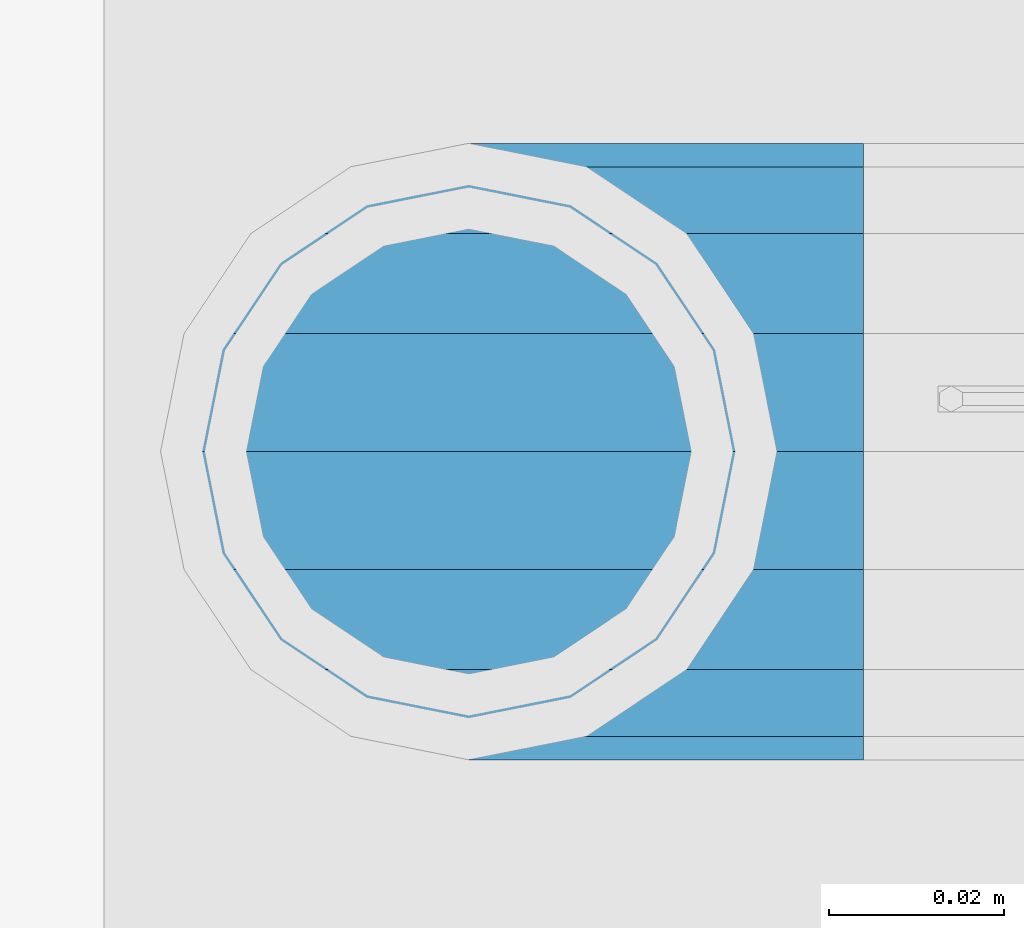
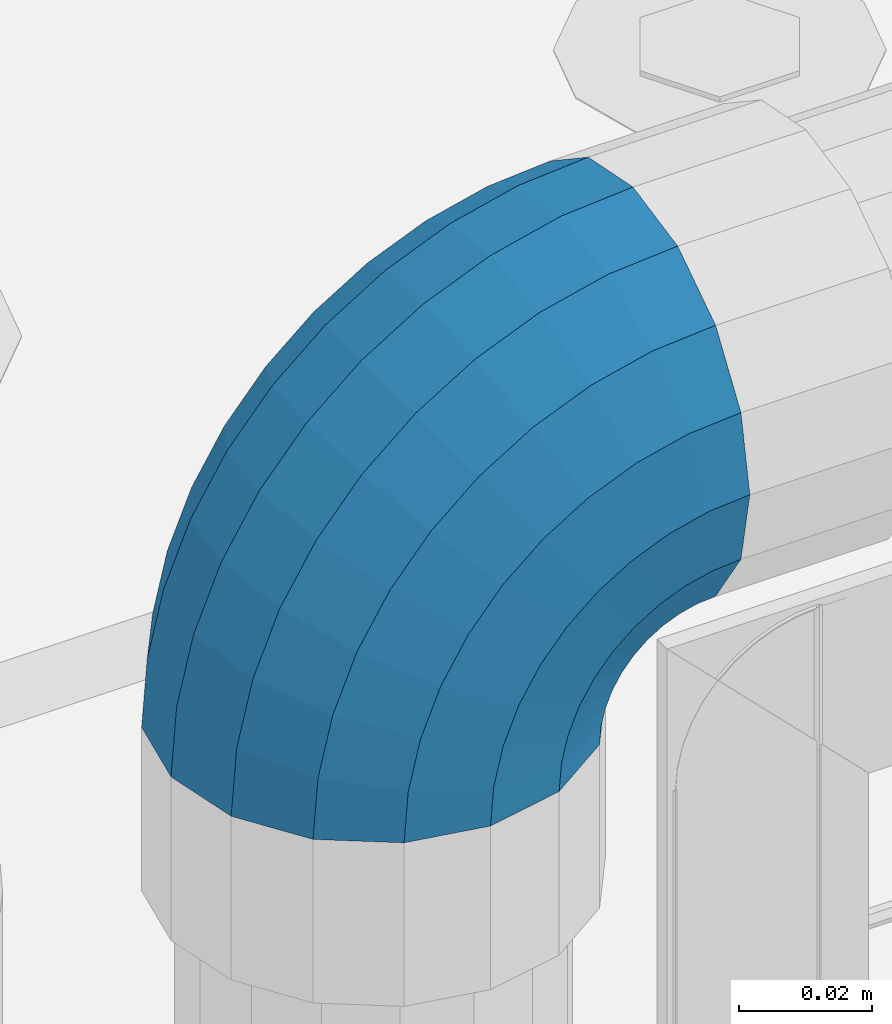
# One storey, part 161 of 240: 1 member.
"""IFC2X3 building model written with IfcOpenShell, lengths in millimetres."""

import ifcopenshell
import ifcopenshell.guid

model = None  # the IFC model being written
_history = None  # IfcOwnerHistory: only IFC2X3 demands one
_inside = {}  # id of a spatial element -> (the spatial element, [elements in it])
_under = {}  # id of a project, library or spatial element -> (it, [spatial elements below it])
_declared = {}  # id of a project -> (the project, [libraries it declares])
_typed = {}  # id of a type object -> (the type object, [elements of that type])
_made_of = {}  # id of a material, layer set ... -> (it, [elements and type objects made of it])


def new_model(schema):
    """Start an empty IFC model of exactly this schema.

    Asked for "IFC4X3", IfcOpenShell would pick the latest addendum, in which some entities
    have other attributes; the version numbers below select the first issue.
    IFC2X3 requires an IfcOwnerHistory on every rooted entity: one is made here for all.
    """
    global model, _history
    if schema == "IFC4X3":
        model = ifcopenshell.file(schema_version=(4, 3, 0, 0))
    else:
        model = ifcopenshell.file(schema=schema)
    _inside.clear()
    _under.clear()
    _declared.clear()
    _typed.clear()
    _made_of.clear()
    _history = None
    if model.schema == "IFC2X3":
        org = make("IfcOrganization", Name="unknown")
        user = make(
            "IfcPersonAndOrganization",
            ThePerson=make("IfcPerson", FamilyName="unknown"),
            TheOrganization=org,
        )
        app = make(
            "IfcApplication",
            ApplicationDeveloper=org,
            Version="unknown",
            ApplicationFullName="unknown",
            ApplicationIdentifier="unknown",
        )
        _history = make(
            "IfcOwnerHistory",
            OwningUser=user,
            OwningApplication=app,
            ChangeAction="ADDED",
            CreationDate=0,
        )
    return model


def make(cls, **values):
    """One entity of the class cls with the attributes given. An attribute that is None is left unset."""
    return model.create_entity(
        cls, **{name: value for name, value in values.items() if value is not None}
    )


def rooted(cls, **values):
    """An entity with a GlobalId (a new one), such as an element, a storey or a relation."""
    return make(cls, GlobalId=ifcopenshell.guid.new(), OwnerHistory=_history, **values)


def si_unit(unit_type, name, prefix=None):
    """IfcSIUnit, for example si_unit("LENGTHUNIT", "METRE", prefix="MILLI")."""
    return make("IfcSIUnit", UnitType=unit_type, Prefix=prefix, Name=name)


def assignment(units):
    """IfcUnitAssignment: the units of a project."""
    return None if units is None else make("IfcUnitAssignment", Units=units)


def point(xyz):
    """IfcCartesianPoint."""
    return None if xyz is None else make("IfcCartesianPoint", Coordinates=xyz)


def direction(xyz):
    """IfcDirection."""
    return None if xyz is None else make("IfcDirection", DirectionRatios=xyz)


def frame(location, z_axis=None, x_axis=None):
    """IfcAxis2Placement3D, a coordinate frame: its origin and axes. An axis left out is left unset."""
    return make(
        "IfcAxis2Placement3D",
        Location=point(location),
        Axis=direction(z_axis),
        RefDirection=direction(x_axis),
    )


def origin_with_axes():
    """The frame at (0, 0, 0) with the z axis (0, 0, 1) and the x axis (1, 0, 0) written out."""
    return frame((0.0, 0.0, 0.0), z_axis=(0.0, 0.0, 1.0), x_axis=(1.0, 0.0, 0.0))


def place(relative_to, where):
    """IfcLocalPlacement: puts the frame where relative to a parent placement (None: the world)."""
    return make(
        "IfcLocalPlacement", PlacementRelTo=relative_to, RelativePlacement=where
    )


def context(
    kind, dimensions, precision=None, world=None, true_north=None, identifier=None
):
    """IfcGeometricRepresentationContext, for example the 3D "Model" context."""
    return make(
        "IfcGeometricRepresentationContext",
        ContextIdentifier=identifier,
        ContextType=kind,
        CoordinateSpaceDimension=dimensions,
        Precision=precision,
        WorldCoordinateSystem=world,
        TrueNorth=true_north,
    )


def subcontext(parent, identifier, kind, view, scale=None):
    """IfcGeometricRepresentationSubContext, for example "Body" below "Model"."""
    return make(
        "IfcGeometricRepresentationSubContext",
        ContextIdentifier=identifier,
        ContextType=kind,
        ParentContext=parent,
        TargetScale=scale,
        TargetView=view,
    )


def project(units=None, contexts=None):
    """IfcProject with its units and contexts."""
    return rooted(
        "IfcProject",
        Name="project",
        RepresentationContexts=contexts,
        UnitsInContext=assignment(units),
    )


def spatial(cls, under=None, at=None, **own):
    """A site, building, storey or space (cls), placed at a placement, below another one or the project."""
    s = rooted(cls, ObjectPlacement=at, **own)
    if under is not None:
        _under.setdefault(under.id(), (under, []))[1].append(s)
    return s


def faces_of(points, faces, orient=None, outer=None):
    """IfcFace entities. A face is a list of loops; a loop is a list of indices into points, from 0.

    orient and outer hold one flag for each loop. By default every Orientation is true, the
    first loop of a face is its IfcFaceOuterBound and the others are IfcFaceBound.
    """
    made = []
    for i, loops in enumerate(faces):
        bounds = []
        for j, loop in enumerate(loops):
            is_outer = j == 0 if outer is None else outer[i][j]
            bounds.append(
                make(
                    "IfcFaceOuterBound" if is_outer else "IfcFaceBound",
                    Bound=make("IfcPolyLoop", Polygon=[points[k] for k in loop]),
                    Orientation=True if orient is None else orient[i][j],
                )
            )
        made.append(make("IfcFace", Bounds=bounds))
    return made


def faceted_brep(points, faces, orient=None, outer=None, voids=None):
    """IfcFacetedBrep: a solid bounded by flat faces; with voids (closed shells), ...WithVoids."""
    shared = [point(p) for p in points]
    hull = make("IfcClosedShell", CfsFaces=faces_of(shared, faces, orient, outer))
    if voids is None:
        return make("IfcFacetedBrep", Outer=hull)
    return make(
        "IfcFacetedBrepWithVoids",
        Outer=hull,
        Voids=[
            make(cls, CfsFaces=faces_of(shared, fs, o, b)) for cls, fs, o, b in voids
        ],
    )


def shape(context_of_items, identifier, shape_type, items):
    """IfcShapeRepresentation: the items that make up one representation, for example the "Body"."""
    return make(
        "IfcShapeRepresentation",
        ContextOfItems=context_of_items,
        RepresentationIdentifier=identifier,
        RepresentationType=shape_type,
        Items=items,
    )


def material(Name=None, Category=None):
    """IfcMaterial."""
    return make("IfcMaterial", Name=Name, Category=Category)


def made_of(thing, what):
    """Note that an element or type object is made of a material, layer set ...; save() writes the relation."""
    if what is not None:
        _made_of.setdefault(what.id(), (what, []))[1].append(thing)
    return thing


def type_object(cls, material=None, **own):
    """A type object (cls), such as IfcWallType, which elements share."""
    return made_of(rooted(cls, **own), material)


def element(
    cls,
    number,
    at=None,
    inside=None,
    cuts=None,
    type_object=None,
    material=None,
    context=None,
    identifier="Body",
    shape_type=None,
    held_by="IfcProductDefinitionShape",
    body=None,
    shapes=None,
    **own,
):
    """One element of the class cls, such as IfcWall. Its Tag is "e" and its number.

    at: its placement. inside: the storey or other place that contains it. cuts: it is an
    opening in that element (IfcRelVoidsElement). A single representation is given by context,
    identifier, shape_type and body (its items); several are given by shapes. held_by: the class
    of the entity that holds the representations. save() writes the other relations.
    """
    e = rooted(cls, Tag="e%d" % number, ObjectPlacement=at, **own)
    if body is not None:
        shapes = [shape(context, identifier, shape_type, body)]
    if shapes is not None:
        e.Representation = make(held_by, Representations=shapes)
    if inside is not None:
        _inside.setdefault(inside.id(), (inside, []))[1].append(e)
    if cuts is not None:
        rooted(
            "IfcRelVoidsElement", RelatingBuildingElement=cuts, RelatedOpeningElement=e
        )
    if type_object is not None:
        _typed.setdefault(type_object.id(), (type_object, []))[1].append(e)
    return made_of(e, material)


def aggregate(whole, parts):
    """IfcRelAggregates: a whole, such as a stair, and the parts it consists of."""
    return rooted("IfcRelAggregates", RelatingObject=whole, RelatedObjects=parts)


def save(model, path):
    """Write the relations noted so far, then the file.

    IfcRelAggregates (storeys below a building ...), IfcRelContainedInSpatialStructure (elements
    in a storey), IfcRelDefinesByType, IfcRelAssociatesMaterial and IfcRelDeclares: one each for
    every whole, place, type object, material and project.
    """
    for whole, parts in _under.values():
        aggregate(whole, parts)
    for where, things in _inside.values():
        rooted(
            "IfcRelContainedInSpatialStructure",
            RelatedElements=things,
            RelatingStructure=where,
        )
    for kind, things in _typed.values():
        rooted("IfcRelDefinesByType", RelatedObjects=things, RelatingType=kind)
    for what, things in _made_of.values():
        rooted("IfcRelAssociatesMaterial", RelatedObjects=things, RelatingMaterial=what)
    for by, libraries in _declared.values():
        rooted("IfcRelDeclares", RelatingContext=by, RelatedDefinitions=libraries)
    model.write(path)


model = new_model("IFC2X3")

# Units and contexts
model_context = context("Model", 3, precision=1e-05, world=origin_with_axes())
body_context = subcontext(model_context, "Body", "Model", "MODEL_VIEW")
ifc_project = project(units=[si_unit("LENGTHUNIT", "METRE", prefix="MILLI"), si_unit("AREAUNIT", "SQUARE_METRE"), si_unit("VOLUMEUNIT", "CUBIC_METRE"), si_unit("MASSUNIT", "GRAM", prefix="KILO"), si_unit("TIMEUNIT", "SECOND"), si_unit("PLANEANGLEUNIT", "RADIAN"), si_unit("SOLIDANGLEUNIT", "STERADIAN"), si_unit("THERMODYNAMICTEMPERATUREUNIT", "DEGREE_CELSIUS"), si_unit("LUMINOUSINTENSITYUNIT", "LUMEN")], contexts=[model_context])

# Site, building, storey
site_placement = place(None, origin_with_axes())
site = spatial("IfcSite", under=ifc_project, at=site_placement, CompositionType="ELEMENT")
building_placement = place(site_placement, origin_with_axes())
building = spatial("IfcBuilding", under=site, at=building_placement, Name="Standard", CompositionType="ELEMENT")
storey_placement = place(building_placement, origin_with_axes())
storey = spatial("IfcBuildingStorey", under=building, at=storey_placement, Name="Undefined", CompositionType="ELEMENT", Elevation=0.0)

# Member
ifc_material = material(Name="Misc_Undefined")
member_type = type_object("IfcMemberType", PredefinedType="NOTDEFINED")
member_placement = place(storey_placement, frame((54781.61, 34664.5, 924.849999999999), z_axis=(-0.707106781186548, 0.0, 0.707106781186548), x_axis=(0.707106781186541, -1.49999999888231e-07, 0.707106781186538)))
element("IfcMember", 1, at=member_placement, inside=storey, type_object=member_type, material=ifc_material, context=body_context, shape_type="Brep", body=[
    faceted_brep([(0.0, -35.1500000000015, 0.0), (9.51152146006643, -32.4743655677739, -9.51152146006643), (13.2759578763362, -32.4743655677739, -6.29638902527222), (5.36946880023606, -35.1500000000015, 4.58595959348168), (17.5749999999971, -24.8548033587067, -17.5749999999971), (19.9787556631127, -24.8548033587067, -15.5219987155579), (22.9628441077002, -13.4513226476338, -22.9628441077002), (24.4574219585265, -13.4513226476338, -21.686354032383), (24.8548033587067, 0.0, -24.8548033587067), (26.0301204183124, 0.0, -23.8509877588003), (22.9628441077002, 13.4513226476338, -22.9628441077002), (24.4574219585265, 13.4513226476338, -21.686354032383), (17.5749999999971, 24.8548033587067, -17.5749999999971), (19.9787556631127, 24.8548033587067, -15.5219987155579), (9.51152146006643, 32.4743655677739, -9.51152146006643), (13.2759578763362, 32.4743655677739, -6.29638902527222), (0.0, 35.1500000000015, 0.0), (5.36946880023606, 35.1500000000015, 4.58595959348168), (-9.51152146007371, 32.4743655677739, 9.51152146007371), (-2.53702027587133, 32.4743655677739, 15.4683082122356), (-17.5749999999971, 24.8548033587067, 17.5750000000044), (-9.23981806264055, 24.8548033587067, 24.6939179025212), (-22.9628441077075, 13.4513226476338, 22.9628441077075), (-13.7184843580544, 13.4513226476338, 30.8582732193609), (-24.8548033587067, 0.0, 24.854803358714), (-15.2911828178476, 0.0, 33.0229069457637), (-22.9628441077075, -13.4513226476338, 22.9628441077075), (-13.7184843580544, -13.4513226476338, 30.8582732193609), (-17.5749999999971, -24.8548033587067, 17.5750000000044), (-9.23981806264055, -24.8548033587067, 24.6939179025212), (-9.51152146007371, -32.4743655677739, 9.51152146007371), (-2.53702027587133, -32.4743655677739, 15.4683082122356), (0.0, -30.3499999999985, 0.0), (-8.21265081971796, -28.0397438117143, 8.21265081971796), (-1.45732902223244, -28.0397438117143, 13.9822406910389), (5.36946880023606, -30.3499999999985, 4.58595959348168), (-15.1750000000029, -21.4606908090136, 15.1750000000029), (-7.24480876131565, -21.4606908090136, 21.9480231689959), (-19.8270929919963, -11.6144421722784, 19.8270929919963), (-11.1118790903492, -11.6144421722784, 27.2705888550845), (-21.4606908090136, 0.0, 21.4606908090136), (-12.46981360684, 0.0, 29.139625372758), (-19.8270929919963, 11.6144421722784, 19.8270929919963), (-11.1118790903492, 11.6144421722784, 27.2705888550845), (-15.1750000000029, 21.4606908090136, 15.1750000000029), (-7.24480876131565, 21.4606908090136, 21.9480231689959), (-8.21265081971796, 28.0397438117143, 8.21265081971796), (-1.45732902223244, 28.0397438117143, 13.9822406910389), (0.0, 30.3499999999985, 0.0), (5.36946880023606, 30.3499999999985, 4.58595959348168), (8.21265081971796, 28.0397438117143, -8.21265081971796), (12.1962666227046, 28.0397438117143, -4.81032150407555), (15.1750000000029, 21.4606908090136, -15.1749999999956), (17.9837463617805, 21.4606908090136, -12.7761039820398), (19.8270929919963, 11.6144421722784, -19.8270929919963), (21.8508166908287, 11.6144421722784, -18.0986696681139), (21.4606908090136, 0.0, -21.4606908090063), (23.2087512073122, 0.0, -19.9677061857947), (19.8270929919963, -11.6144421722784, -19.8270929919963), (21.8508166908287, -11.6144421722784, -18.0986696681139), (15.1750000000029, -21.4606908090136, -15.1749999999956), (17.9837463617805, -21.4606908090136, -12.7761039820398), (8.21265081971796, -28.0397438117143, -8.21265081971796), (12.1962666227046, -28.0397438117143, -4.81032150407555), (17.4970053560755, -32.4743655677739, -3.70972780291777), (11.390232665115, -35.1500000000015, 8.27548843508703), (22.6740772628618, -24.8548033587067, -13.8703035149447), (26.1332861179544, -13.4513226476338, -20.6593831546707), (27.347998730962, 0.0, -23.0433908901396), (26.1332861179544, 13.4513226476338, -20.6593831546707), (22.6740772628618, 24.8548033587067, -13.8703035149447), (17.4970053560755, 32.4743655677739, -3.70972780291777), (11.390232665115, 35.1500000000015, 8.27548843508703), (5.28345997416181, 32.4743655677739, 20.2607046730918), (0.106388067375519, 24.8548033587067, 30.4212803851042), (-3.35282078771706, 13.4513226476338, 37.210360024852), (-4.56753340072464, 0.0, 39.5943677603063), (-3.35282078771706, -13.4513226476338, 37.210360024852), (0.106388067375519, -24.8548033587067, 30.4212803851042), (5.28345997416181, -32.4743655677739, 20.2607046730918), (6.11738625913131, -28.0397438117143, 18.6240321853984), (11.390232665115, -30.3499999999985, 8.27548843508703), (1.64728291997744, -21.4606908090136, 27.3971039595053), (-1.33954464053386, -11.6144421722784, 33.2590831078996), (-2.38837900197541, 0.0, 35.3175364442068), (-1.33954464053386, 11.6144421722784, 33.2590831078996), (1.64728291997744, 21.4606908090136, 27.3971039595053), (6.11738625913131, 28.0397438117143, 18.6240321853984), (11.390232665115, 30.3499999999985, 8.27548843508703), (16.663079071106, 28.0397438117143, -2.07305531522434), (21.1331824102599, 21.4606908090136, -10.8461270893313), (24.1200099707639, 11.6144421722784, -16.7081062377256), (25.1688443322128, 0.0, -18.7665595740255), (24.1200099707639, -11.6144421722784, -16.7081062377256), (21.1331824102599, -21.4606908090136, -10.8461270893313), (16.663079071106, -28.0397438117143, -2.07305531522434), (22.070727701459, -32.4743655677739, -1.81522997692809), (17.9140404065256, -35.1500000000015, 10.9777380798914), (25.5945970362081, -24.8548033587067, -12.6605846156453), (27.9491712485105, -13.4513226476338, -19.9072189058861), (28.7759877588032, 0.0, -22.4518984678798), (27.9491712485105, 13.4513226476338, -19.9072189058861), (25.5945970362081, 24.8548033587067, -12.6605846156453), (22.070727701459, 32.4743655677739, -1.81522997692809), (17.9140404065256, 35.1500000000015, 10.9777380798914), (13.7573531115777, 32.4743655677739, 23.7707061367109), (10.2334837768358, 24.8548033587067, 34.6160607754209), (7.87890956454066, 13.4513226476338, 41.862695065669), (7.05209305424796, 0.0, 44.4073746276699), (7.87890956454066, -13.4513226476338, 41.862695065669), (10.2334837768358, -24.8548033587067, 34.6160607754209), (13.7573531115777, -32.4743655677739, 23.7707061367109), (14.3249803951039, -28.0397438117143, 22.023728990971), (17.9140404065256, -30.3499999999985, 10.9777380798914), (11.2823222355146, -21.4606908090136, 31.3880679180002), (9.24928305078356, -11.6144421722784, 37.6451191472734), (8.53537462724489, 0.0, 39.8423033494473), (9.24928305078356, 11.6144421722784, 37.6451191472734), (11.2823222355146, 21.4606908090136, 31.3880679180002), (14.3249803951039, 28.0397438117143, 22.023728990971), (17.9140404065256, 30.3499999999985, 10.9777380798914), (21.5031004179473, 28.0397438117143, -0.0682528311954229), (24.5457585775293, 21.4606908090136, -9.43259175821731), (26.5787977622676, 11.6144421722784, -15.6896429874905), (27.2927061858063, 0.0, -17.8868271896717), (26.5787977622676, -11.6144421722784, -15.6896429874905), (24.5457585775293, -21.4606908090136, -9.43259175821731), (21.5031004179473, -28.0397438117143, -0.0682528311954229), (26.8845046890492, -32.4743655677739, -0.659544371257653), (24.7802542265854, -35.1500000000015, 12.6261701733893), (28.6684020936882, -24.8548033587067, -11.9226293117827), (29.860364231703, -13.4513226476338, -19.4483820661189), (30.2789256727556, 0.0, -22.0910749985269), (29.860364231703, 13.4513226476338, -19.4483820661189), (28.6684020936882, 24.8548033587067, -11.9226293117827), (26.8845046890492, 32.4743655677739, -0.659544371257653), (24.7802542265854, 35.1500000000015, 12.6261701733893), (22.6760037641216, 32.4743655677739, 25.9118847180362), (20.8921063594826, 24.8548033587067, 37.1749696585684), (19.7001442214678, 13.4513226476338, 44.7007224129047), (19.2815827804225, 0.0, 47.3434153453127), (19.7001442214678, -13.4513226476338, 44.7007224129047), (20.8921063594826, -24.8548033587067, 37.1749696585684), (22.6760037641216, -32.4743655677739, 25.9118847180362), (22.9633551786319, -28.0397438117143, 24.0976192894668), (24.7802542265854, -30.3499999999985, 12.6261701733893), (21.4230625404889, -21.4606908090136, 33.8226442665691), (20.3938719035359, -11.6144421722784, 40.3206982095071), (20.0324682126156, 0.0, 42.6025113104479), (20.3938719035359, 11.6144421722784, 40.3206982095071), (21.4230625404889, 21.4606908090136, 33.8226442665691), (22.9633551786319, 28.0397438117143, 24.0976192894668), (24.7802542265854, 30.3499999999985, 12.6261701733893), (26.5971532745461, 28.0397438117143, 1.15472105731169), (28.1374459126891, 21.4606908090136, -8.57030391978333), (29.1666365496349, 11.6144421722784, -15.0683578627213), (29.5280402405551, 0.0, -17.3501709636694), (29.1666365496349, -11.6144421722784, -15.0683578627213), (28.1374459126891, -21.4606908090136, -8.57030391978333), (26.5971532745461, -28.0397438117143, 1.15472105731169), (31.8198051533982, -32.4743655677739, -0.271127801024704), (31.8198051533909, -35.1500000000015, 13.1801948466091), (31.8198051533982, -24.8548033587067, -11.6746085120976), (31.8198051533909, -13.4513226476338, -19.2941707211648), (31.8198051533982, 0.0, -21.9698051533924), (31.8198051533909, 13.4513226476338, -19.2941707211648), (31.8198051533982, 24.8548033587067, -11.6746085120976), (31.8198051533982, 32.4743655677739, -0.271127801024704), (31.8198051533909, 35.1500000000015, 13.1801948466091), (31.8198051533982, 32.4743655677739, 26.6315174942429), (31.8198051533982, 24.8548033587067, 38.0349982053158), (31.8198051533909, 13.4513226476338, 45.654560414383), (31.8198051533982, 0.0, 48.3301948466178), (31.8198051533909, -13.4513226476338, 45.654560414383), (31.8198051533982, -24.8548033587067, 38.0349982053158), (31.8198051533982, -32.4743655677739, 26.6315174942429), (31.8198051533982, -28.0397438117143, 24.7946370188947), (31.8198051533909, -30.3499999999985, 13.1801948466091), (31.8198051533982, -21.4606908090136, 34.6408856556227), (31.8198051533982, -11.6144421722784, 41.2199386583306), (31.8198051533982, 0.0, 43.5301948466076), (31.8198051533982, 11.6144421722784, 41.2199386583306), (31.8198051533982, 21.4606908090136, 34.6408856556227), (31.8198051533982, 28.0397438117143, 24.7946370188947), (31.8198051533909, 30.3499999999985, 13.1801948466091), (31.8198051533982, 28.0397438117143, 1.56575267433072), (31.8198051533982, 21.4606908090136, -8.28049596239725), (31.8198051533982, 11.6144421722784, -14.8595489651125), (31.8198051533982, 0.0, -17.1698051533895), (31.8198051533982, -11.6144421722784, -14.8595489651125), (31.8198051533982, -21.4606908090136, -8.28049596239725), (31.8198051533982, -28.0397438117143, 1.56575267433072), (36.7551056177399, -32.4743655677739, -0.659544371264928), (38.859356080211, -35.1500000000015, 12.6261701733965), (34.9712082131082, -24.8548033587067, -11.9226293117899), (33.7792460750934, -13.4513226476338, -19.4483820661189), (33.3606846340408, 0.0, -22.0910749985342), (33.7792460750934, 13.4513226476338, -19.4483820661189), (34.9712082131082, 24.8548033587067, -11.9226293117899), (36.7551056177399, 32.4743655677739, -0.659544371264928), (38.859356080211, 35.1500000000015, 12.6261701733965), (40.9636065426675, 32.4743655677739, 25.9118847180434), (42.7475039473065, 24.8548033587067, 37.1749696585684), (43.9394660853213, 13.4513226476338, 44.7007224129047), (44.3580275263739, 0.0, 47.3434153453054), (43.9394660853213, -13.4513226476338, 44.7007224129047), (42.7475039473065, -24.8548033587067, 37.1749696585684), (40.9636065426675, -32.4743655677739, 25.9118847180434), (40.6762551281645, -28.0397438117143, 24.0976192894668), (38.859356080211, -30.3499999999985, 12.6261701733965), (42.2165477663075, -21.4606908090136, 33.8226442665691), (43.2457384032605, -11.6144421722784, 40.3206982094998), (43.6071420941807, 0.0, 42.6025113104552), (43.2457384032605, 11.6144421722784, 40.3206982094998), (42.2165477663075, 21.4606908090136, 33.8226442665691), (40.6762551281645, 28.0397438117143, 24.0976192894668), (38.859356080211, 30.3499999999985, 12.6261701733965), (37.042457032243, 28.0397438117143, 1.15472105731169), (35.5021643941072, 21.4606908090136, -8.57030391978333), (34.4729737571543, 11.6144421722784, -15.068357862714), (34.111570066234, 0.0, -17.3501709636694), (34.4729737571543, -11.6144421722784, -15.068357862714), (35.5021643941072, -21.4606908090136, -8.57030391978333), (37.042457032243, -28.0397438117143, 1.15472105731169), (41.5688826053301, -32.4743655677739, -1.81522997692809), (45.7255699002708, -35.1500000000015, 10.9777380798987), (38.0450132705882, -24.8548033587067, -12.6605846156381), (35.6904390582786, -13.4513226476338, -19.9072189058934), (34.8636225479859, 0.0, -22.4518984678871), (35.6904390582786, 13.4513226476338, -19.9072189058934), (38.0450132705882, 24.8548033587067, -12.6605846156381), (41.5688826053301, 32.4743655677739, -1.81522997692809), (45.7255699002708, 35.1500000000015, 10.9777380798987), (49.8822571952041, 32.4743655677739, 23.7707061367109), (53.4061265299533, 24.8548033587067, 34.6160607754282), (55.7607007422557, 13.4513226476338, 41.862695065669), (56.5875172525484, 0.0, 44.4073746276626), (55.7607007422557, -13.4513226476338, 41.862695065669), (53.4061265299533, -24.8548033587067, 34.6160607754282), (49.8822571952041, -32.4743655677739, 23.7707061367109), (49.3146299116925, -28.0397438117143, 22.023728990971), (45.7255699002708, -30.3499999999985, 10.9777380798987), (52.3572880712745, -21.4606908090136, 31.3880679180002), (54.3903272560128, -11.6144421722784, 37.6451191472734), (55.1042356795515, 0.0, 39.8423033494473), (54.3903272560128, 11.6144421722784, 37.6451191472734), (52.3572880712745, 21.4606908090136, 31.3880679180002), (49.3146299116925, 28.0397438117143, 22.023728990971), (45.7255699002708, 30.3499999999985, 10.9777380798987), (42.1365098888491, 28.0397438117143, -0.068252831188147), (39.0938517292598, 21.4606908090136, -9.43259175821731), (37.0608125445287, 11.6144421722784, -15.6896429874905), (36.3469041209901, 0.0, -17.8868271896645), (37.0608125445287, -11.6144421722784, -15.6896429874905), (39.0938517292598, -21.4606908090136, -9.43259175821731), (42.1365098888491, -28.0397438117143, -0.068252831188147), (46.1426049507209, -32.4743655677739, -3.70972780291777), (52.2493776416741, -35.1500000000015, 8.27548843508703), (40.9655330439346, -24.8548033587067, -13.8703035149374), (37.506324188842, -13.4513226476338, -20.6593831546707), (36.2916115758271, 0.0, -23.0433908901323), (37.506324188842, 13.4513226476338, -20.6593831546707), (40.9655330439346, 24.8548033587067, -13.8703035149374), (46.1426049507209, 32.4743655677739, -3.70972780291777), (52.2493776416741, 35.1500000000015, 8.27548843508703), (58.3561503326346, 32.4743655677739, 20.2607046730918), (63.5332222394209, 24.8548033587067, 30.4212803851115), (66.9924310945134, 13.4513226476338, 37.2103600248447), (68.207143707521, 0.0, 39.5943677603063), (66.9924310945134, -13.4513226476338, 37.2103600248447), (63.5332222394209, -24.8548033587067, 30.4212803851115), (58.3561503326346, -32.4743655677739, 20.2607046730918), (57.5222240476651, -28.0397438117143, 18.6240321853984), (52.2493776416741, -30.3499999999985, 8.27548843508703), (61.9923273868189, -21.4606908090136, 27.3971039594981), (64.979154947323, -11.6144421722784, 33.2590831078924), (66.0279893087718, 0.0, 35.3175364442068), (64.979154947323, 11.6144421722784, 33.2590831078924), (61.9923273868189, 21.4606908090136, 27.3971039594981), (57.5222240476651, 28.0397438117143, 18.6240321853984), (52.2493776416741, 30.3499999999985, 8.27548843508703), (46.9765312356903, 28.0397438117143, -2.07305531523161), (42.5064278965365, 21.4606908090136, -10.8461270893313), (39.5196003360252, 11.6144421722784, -16.7081062377256), (38.4707659745836, 0.0, -18.7665595740327), (39.5196003360252, -11.6144421722784, -16.7081062377256), (42.5064278965365, -21.4606908090136, -10.8461270893313), (46.9765312356903, -28.0397438117143, -2.07305531523161), (50.3636524304529, -32.4743655677739, -6.2963890252795), (58.2701415065603, -35.1500000000015, 4.58595959348895), (43.6608546436837, -24.8548033587067, -15.5219987155579), (39.1821883482698, -13.4513226476338, -21.6863540323902), (37.6094898884767, 0.0, -23.8509877587931), (39.1821883482698, 13.4513226476338, -21.6863540323902), (43.6608546436837, 24.8548033587067, -15.5219987155579), (50.3636524304529, 32.4743655677739, -6.2963890252795), (58.2701415065603, 35.1500000000015, 4.58595959348895), (66.1766305826604, 32.4743655677739, 15.4683082122356), (72.8794283694297, 24.8548033587067, 24.6939179025212), (77.3580946648508, 13.4513226476338, 30.8582732193536), (78.9307931246367, 0.0, 33.0229069457637), (77.3580946648508, -13.4513226476338, 30.8582732193536), (72.8794283694297, -24.8548033587067, 24.6939179025212), (66.1766305826604, -32.4743655677739, 15.4683082122356), (65.0969393290288, -28.0397438117143, 13.9822406910462), (58.2701415065603, -30.3499999999985, 4.58595959348895), (70.884419068112, -21.4606908090136, 21.9480231689959), (74.7514893971456, -11.6144421722784, 27.2705888550845), (76.1094239136364, 0.0, 29.139625372758), (74.7514893971456, 11.6144421722784, 27.2705888550845), (70.884419068112, 21.4606908090136, 21.9480231689959), (65.0969393290288, 28.0397438117143, 13.9822406910462), (58.2701415065603, 30.3499999999985, 4.58595959348895), (51.4433436840845, 28.0397438117143, -4.81032150407555), (45.6558639450086, 21.4606908090136, -12.7761039820325), (41.7887936159677, 11.6144421722784, -18.0986696681211), (40.4308590994842, 0.0, -19.9677061858019), (41.7887936159677, -11.6144421722784, -18.0986696681211), (45.6558639450086, -21.4606908090136, -12.7761039820325), (51.4433436840845, -28.0397438117143, -4.81032150407555), (54.1280888467154, -32.4743655677739, -9.51152146006643), (63.6396103067891, -35.1500000000015, 7.27595761418343e-12), (46.0646103067847, -24.8548033587067, -17.5749999999971), (40.6767661990889, -13.4513226476338, -22.9628441077002), (38.7848069480824, 0.0, -24.8548033586994), (40.6767661990889, 13.4513226476338, -22.9628441077002), (46.0646103067847, 24.8548033587067, -17.5749999999971), (54.1280888467154, 32.4743655677739, -9.51152146006643), (63.6396103067891, 35.1500000000015, 7.27595761418343e-12), (73.1511317668555, 32.4743655677739, 9.51152146007371), (81.2146103067862, 24.8548033587067, 17.5750000000044), (86.6024544144893, 13.4513226476338, 22.9628441077075), (88.4944136654958, 0.0, 24.854803358714), (86.6024544144893, -13.4513226476338, 22.9628441077075), (81.2146103067862, -24.8548033587067, 17.5750000000044), (73.1511317668555, -32.4743655677739, 9.51152146007371), (71.8522611265071, -28.0397438117143, 8.21265081972524), (63.6396103067891, -30.3499999999985, 7.27595761418343e-12), (78.8146103067847, -21.4606908090136, 15.1750000000029), (83.4667032987854, -11.6144421722784, 19.8270929920036), (85.1003011158027, 0.0, 21.4606908090136), (83.4667032987854, 11.6144421722784, 19.8270929920036), (78.8146103067847, 21.4606908090136, 15.1750000000029), (71.8522611265071, 28.0397438117143, 8.21265081972524), (63.6396103067891, 30.3499999999985, 7.27595761418343e-12), (55.4269594870711, 28.0397438117143, -8.21265081971069), (48.4646103067862, 21.4606908090136, -15.1749999999956), (43.8125173147855, 11.6144421722784, -19.8270929919963), (42.1789194977755, 0.0, -21.4606908090063), (43.8125173147855, -11.6144421722784, -19.8270929919963), (48.4646103067862, -21.4606908090136, -15.1749999999956), (55.4269594870711, -28.0397438117143, -8.21265081971069)], [[[0, 1, 2, 3]], [[1, 4, 5, 2]], [[4, 6, 7, 5]], [[6, 8, 9, 7]], [[8, 10, 11, 9]], [[10, 12, 13, 11]], [[12, 14, 15, 13]], [[14, 16, 17, 15]], [[16, 18, 19, 17]], [[18, 20, 21, 19]], [[20, 22, 23, 21]], [[22, 24, 25, 23]], [[24, 26, 27, 25]], [[26, 28, 29, 27]], [[28, 30, 31, 29]], [[30, 0, 3, 31]], [[32, 33, 34, 35]], [[33, 36, 37, 34]], [[36, 38, 39, 37]], [[38, 40, 41, 39]], [[40, 42, 43, 41]], [[42, 44, 45, 43]], [[44, 46, 47, 45]], [[46, 48, 49, 47]], [[48, 50, 51, 49]], [[50, 52, 53, 51]], [[52, 54, 55, 53]], [[54, 56, 57, 55]], [[56, 58, 59, 57]], [[58, 60, 61, 59]], [[60, 62, 63, 61]], [[62, 32, 35, 63]], [[30, 28, 26, 24, 22, 20, 18, 16, 14, 12, 10, 8, 6, 4, 1, 0], [62, 60, 58, 56, 54, 52, 50, 48, 46, 44, 42, 40, 38, 36, 33, 32]], [[3, 2, 64, 65]], [[2, 5, 66, 64]], [[5, 7, 67, 66]], [[7, 9, 68, 67]], [[9, 11, 69, 68]], [[11, 13, 70, 69]], [[13, 15, 71, 70]], [[15, 17, 72, 71]], [[17, 19, 73, 72]], [[19, 21, 74, 73]], [[21, 23, 75, 74]], [[23, 25, 76, 75]], [[25, 27, 77, 76]], [[27, 29, 78, 77]], [[29, 31, 79, 78]], [[31, 3, 65, 79]], [[35, 34, 80, 81]], [[34, 37, 82, 80]], [[37, 39, 83, 82]], [[39, 41, 84, 83]], [[41, 43, 85, 84]], [[43, 45, 86, 85]], [[45, 47, 87, 86]], [[47, 49, 88, 87]], [[49, 51, 89, 88]], [[51, 53, 90, 89]], [[53, 55, 91, 90]], [[55, 57, 92, 91]], [[57, 59, 93, 92]], [[59, 61, 94, 93]], [[61, 63, 95, 94]], [[63, 35, 81, 95]], [[65, 64, 96, 97]], [[64, 66, 98, 96]], [[66, 67, 99, 98]], [[67, 68, 100, 99]], [[68, 69, 101, 100]], [[69, 70, 102, 101]], [[70, 71, 103, 102]], [[71, 72, 104, 103]], [[72, 73, 105, 104]], [[73, 74, 106, 105]], [[74, 75, 107, 106]], [[75, 76, 108, 107]], [[76, 77, 109, 108]], [[77, 78, 110, 109]], [[78, 79, 111, 110]], [[79, 65, 97, 111]], [[81, 80, 112, 113]], [[80, 82, 114, 112]], [[82, 83, 115, 114]], [[83, 84, 116, 115]], [[84, 85, 117, 116]], [[85, 86, 118, 117]], [[86, 87, 119, 118]], [[87, 88, 120, 119]], [[88, 89, 121, 120]], [[89, 90, 122, 121]], [[90, 91, 123, 122]], [[91, 92, 124, 123]], [[92, 93, 125, 124]], [[93, 94, 126, 125]], [[94, 95, 127, 126]], [[95, 81, 113, 127]], [[97, 96, 128, 129]], [[96, 98, 130, 128]], [[98, 99, 131, 130]], [[99, 100, 132, 131]], [[100, 101, 133, 132]], [[101, 102, 134, 133]], [[102, 103, 135, 134]], [[103, 104, 136, 135]], [[104, 105, 137, 136]], [[105, 106, 138, 137]], [[106, 107, 139, 138]], [[107, 108, 140, 139]], [[108, 109, 141, 140]], [[109, 110, 142, 141]], [[110, 111, 143, 142]], [[111, 97, 129, 143]], [[113, 112, 144, 145]], [[112, 114, 146, 144]], [[114, 115, 147, 146]], [[115, 116, 148, 147]], [[116, 117, 149, 148]], [[117, 118, 150, 149]], [[118, 119, 151, 150]], [[119, 120, 152, 151]], [[120, 121, 153, 152]], [[121, 122, 154, 153]], [[122, 123, 155, 154]], [[123, 124, 156, 155]], [[124, 125, 157, 156]], [[125, 126, 158, 157]], [[126, 127, 159, 158]], [[127, 113, 145, 159]], [[129, 128, 160, 161]], [[128, 130, 162, 160]], [[130, 131, 163, 162]], [[131, 132, 164, 163]], [[132, 133, 165, 164]], [[133, 134, 166, 165]], [[134, 135, 167, 166]], [[135, 136, 168, 167]], [[136, 137, 169, 168]], [[137, 138, 170, 169]], [[138, 139, 171, 170]], [[139, 140, 172, 171]], [[140, 141, 173, 172]], [[141, 142, 174, 173]], [[142, 143, 175, 174]], [[143, 129, 161, 175]], [[145, 144, 176, 177]], [[144, 146, 178, 176]], [[146, 147, 179, 178]], [[147, 148, 180, 179]], [[148, 149, 181, 180]], [[149, 150, 182, 181]], [[150, 151, 183, 182]], [[151, 152, 184, 183]], [[152, 153, 185, 184]], [[153, 154, 186, 185]], [[154, 155, 187, 186]], [[155, 156, 188, 187]], [[156, 157, 189, 188]], [[157, 158, 190, 189]], [[158, 159, 191, 190]], [[159, 145, 177, 191]], [[161, 160, 192, 193]], [[160, 162, 194, 192]], [[162, 163, 195, 194]], [[163, 164, 196, 195]], [[164, 165, 197, 196]], [[165, 166, 198, 197]], [[166, 167, 199, 198]], [[167, 168, 200, 199]], [[168, 169, 201, 200]], [[169, 170, 202, 201]], [[170, 171, 203, 202]], [[171, 172, 204, 203]], [[172, 173, 205, 204]], [[173, 174, 206, 205]], [[174, 175, 207, 206]], [[175, 161, 193, 207]], [[177, 176, 208, 209]], [[176, 178, 210, 208]], [[178, 179, 211, 210]], [[179, 180, 212, 211]], [[180, 181, 213, 212]], [[181, 182, 214, 213]], [[182, 183, 215, 214]], [[183, 184, 216, 215]], [[184, 185, 217, 216]], [[185, 186, 218, 217]], [[186, 187, 219, 218]], [[187, 188, 220, 219]], [[188, 189, 221, 220]], [[189, 190, 222, 221]], [[190, 191, 223, 222]], [[191, 177, 209, 223]], [[193, 192, 224, 225]], [[192, 194, 226, 224]], [[194, 195, 227, 226]], [[195, 196, 228, 227]], [[196, 197, 229, 228]], [[197, 198, 230, 229]], [[198, 199, 231, 230]], [[199, 200, 232, 231]], [[200, 201, 233, 232]], [[201, 202, 234, 233]], [[202, 203, 235, 234]], [[203, 204, 236, 235]], [[204, 205, 237, 236]], [[205, 206, 238, 237]], [[206, 207, 239, 238]], [[207, 193, 225, 239]], [[209, 208, 240, 241]], [[208, 210, 242, 240]], [[210, 211, 243, 242]], [[211, 212, 244, 243]], [[212, 213, 245, 244]], [[213, 214, 246, 245]], [[214, 215, 247, 246]], [[215, 216, 248, 247]], [[216, 217, 249, 248]], [[217, 218, 250, 249]], [[218, 219, 251, 250]], [[219, 220, 252, 251]], [[220, 221, 253, 252]], [[221, 222, 254, 253]], [[222, 223, 255, 254]], [[223, 209, 241, 255]], [[225, 224, 256, 257]], [[224, 226, 258, 256]], [[226, 227, 259, 258]], [[227, 228, 260, 259]], [[228, 229, 261, 260]], [[229, 230, 262, 261]], [[230, 231, 263, 262]], [[231, 232, 264, 263]], [[232, 233, 265, 264]], [[233, 234, 266, 265]], [[234, 235, 267, 266]], [[235, 236, 268, 267]], [[236, 237, 269, 268]], [[237, 238, 270, 269]], [[238, 239, 271, 270]], [[239, 225, 257, 271]], [[241, 240, 272, 273]], [[240, 242, 274, 272]], [[242, 243, 275, 274]], [[243, 244, 276, 275]], [[244, 245, 277, 276]], [[245, 246, 278, 277]], [[246, 247, 279, 278]], [[247, 248, 280, 279]], [[248, 249, 281, 280]], [[249, 250, 282, 281]], [[250, 251, 283, 282]], [[251, 252, 284, 283]], [[252, 253, 285, 284]], [[253, 254, 286, 285]], [[254, 255, 287, 286]], [[255, 241, 273, 287]], [[257, 256, 288, 289]], [[256, 258, 290, 288]], [[258, 259, 291, 290]], [[259, 260, 292, 291]], [[260, 261, 293, 292]], [[261, 262, 294, 293]], [[262, 263, 295, 294]], [[263, 264, 296, 295]], [[264, 265, 297, 296]], [[265, 266, 298, 297]], [[266, 267, 299, 298]], [[267, 268, 300, 299]], [[268, 269, 301, 300]], [[269, 270, 302, 301]], [[270, 271, 303, 302]], [[271, 257, 289, 303]], [[273, 272, 304, 305]], [[272, 274, 306, 304]], [[274, 275, 307, 306]], [[275, 276, 308, 307]], [[276, 277, 309, 308]], [[277, 278, 310, 309]], [[278, 279, 311, 310]], [[279, 280, 312, 311]], [[280, 281, 313, 312]], [[281, 282, 314, 313]], [[282, 283, 315, 314]], [[283, 284, 316, 315]], [[284, 285, 317, 316]], [[285, 286, 318, 317]], [[286, 287, 319, 318]], [[287, 273, 305, 319]], [[289, 288, 320, 321]], [[288, 290, 322, 320]], [[290, 291, 323, 322]], [[291, 292, 324, 323]], [[292, 293, 325, 324]], [[293, 294, 326, 325]], [[294, 295, 327, 326]], [[295, 296, 328, 327]], [[296, 297, 329, 328]], [[297, 298, 330, 329]], [[298, 299, 331, 330]], [[299, 300, 332, 331]], [[300, 301, 333, 332]], [[301, 302, 334, 333]], [[302, 303, 335, 334]], [[303, 289, 321, 335]], [[305, 304, 336, 337]], [[304, 306, 338, 336]], [[306, 307, 339, 338]], [[307, 308, 340, 339]], [[308, 309, 341, 340]], [[309, 310, 342, 341]], [[310, 311, 343, 342]], [[311, 312, 344, 343]], [[312, 313, 345, 344]], [[313, 314, 346, 345]], [[314, 315, 347, 346]], [[315, 316, 348, 347]], [[316, 317, 349, 348]], [[317, 318, 350, 349]], [[318, 319, 351, 350]], [[319, 305, 337, 351]], [[322, 323, 324, 325, 326, 327, 328, 329, 330, 331, 332, 333, 334, 335, 321, 320], [338, 339, 340, 341, 342, 343, 344, 345, 346, 347, 348, 349, 350, 351, 337, 336]]]),
])

save(model, "model.ifc")
